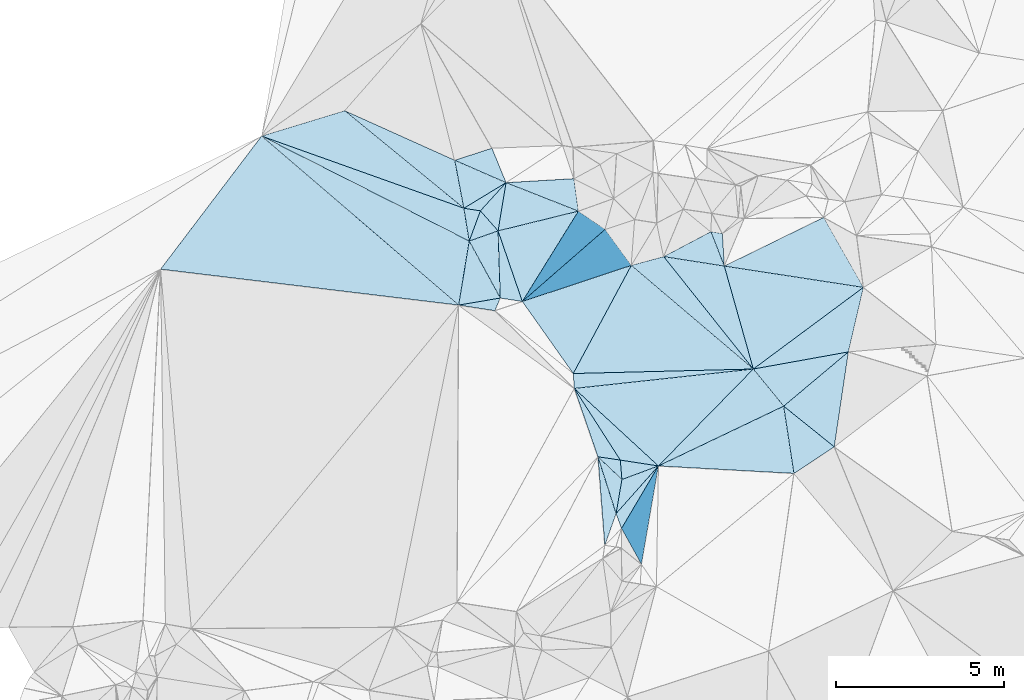
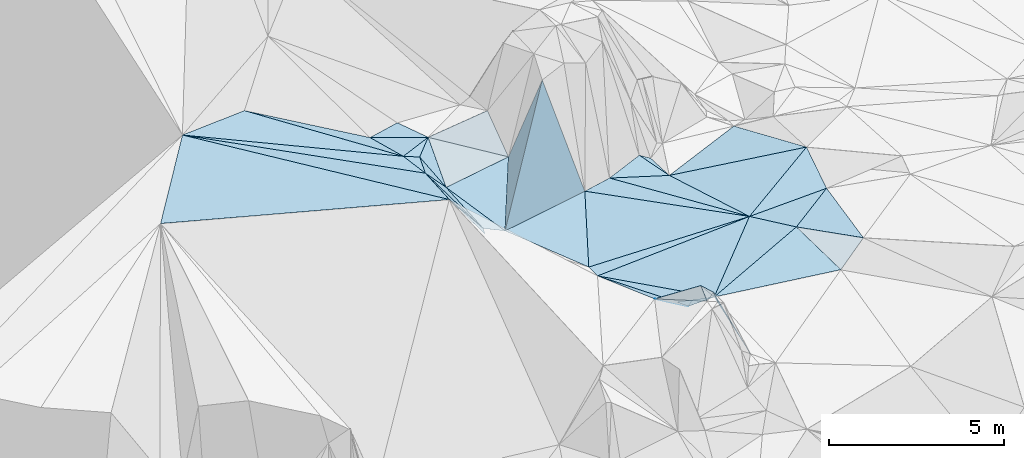
# One storey, part 122 of 275: 45 plates.
"""IFC2X3 building model written with IfcOpenShell, lengths in millimetres."""

from ifc_helpers import new_model, si_unit, frame, origin_with_axes, place, context, subcontext, project, spatial, polyline, outline, extrude, material, type_object, element, save


model = new_model("IFC2X3")

# Units and contexts
model_context = context("Model", 3, precision=1e-05, world=origin_with_axes())
body_context = subcontext(model_context, "Body", "Model", "MODEL_VIEW")
ifc_project = project(units=[si_unit("LENGTHUNIT", "METRE", prefix="MILLI"), si_unit("AREAUNIT", "SQUARE_METRE"), si_unit("VOLUMEUNIT", "CUBIC_METRE"), si_unit("MASSUNIT", "GRAM", prefix="KILO"), si_unit("TIMEUNIT", "SECOND"), si_unit("PLANEANGLEUNIT", "RADIAN"), si_unit("SOLIDANGLEUNIT", "STERADIAN"), si_unit("THERMODYNAMICTEMPERATUREUNIT", "DEGREE_CELSIUS"), si_unit("LUMINOUSINTENSITYUNIT", "LUMEN")], contexts=[model_context])

# Site, building, storey
site_placement = place(None, origin_with_axes())
site = spatial("IfcSite", under=ifc_project, at=site_placement, CompositionType="ELEMENT")
building_placement = place(site_placement, origin_with_axes())
building = spatial("IfcBuilding", under=site, at=building_placement, Name="Undefined", CompositionType="ELEMENT")
storey_placement = place(building_placement, origin_with_axes())
storey = spatial("IfcBuildingStorey", under=building, at=storey_placement, Name="Undefined", CompositionType="ELEMENT", Elevation=0.0)

# Plates
ifc_material = material()
plate_type_1 = type_object("IfcPlateType", PredefinedType="NOTDEFINED")
plate_1_placement = place(storey_placement, frame((-117256.863583798, 103758.167363246, 53639.5008489211), z_axis=(-0.0499357996180715, 0.0315971887779537, -0.99825248989313), x_axis=(-0.760955833681114, 0.646159315420978, 0.0585180167245527)))
element("IfcPlate", 1, at=plate_1_placement, inside=storey, type_object=plate_type_1, material=ifc_material, Name="00", context=body_context, shape_type="SweptSolid", body=[
    extrude(outline(polyline([(0.0, 0.0), (4784.85107421875, -8.87303031049669e-09), (4217.3515625, 825.920349121094), (0.0, 0.0)])), frame((-8.85201319254618e-08, 2.18876761149539e-07, -0.5000001331573), z_axis=(0.0, 0.0, 1.0), x_axis=(1.0, 0.0, 0.0)), (0.0, 0.0, 1.0), 1.0),
])
plate_type_2 = type_object("IfcPlateType", PredefinedType="NOTDEFINED")
plate_2_placement = place(storey_placement, frame((-116351.3289521, 102649.731812888, 53629.5089656912), z_axis=(-0.0704390174339977, 0.175137384942136, -0.982020998359283), x_axis=(0.14899523720596, -0.971575277584315, -0.183961678827142)))
element("IfcPlate", 2, at=plate_2_placement, inside=storey, type_object=plate_type_2, material=ifc_material, Name="00", context=body_context, shape_type="SweptSolid", body=[
    extrude(outline(polyline([(0.0, 0.0), (2065.64770507813, -8.04720912128687e-09), (1185.29418945313, 3968.82568359375), (0.0, 0.0)])), frame((-8.85201319254618e-08, 2.18876761149539e-07, -0.5000001331573), z_axis=(0.0, 0.0, 1.0), x_axis=(1.0, 0.0, 0.0)), (0.0, 0.0, 1.0), 1.0),
])
plate_type_3 = type_object("IfcPlateType", PredefinedType="NOTDEFINED")
plate_3_placement = place(storey_placement, frame((-125734.75211419, 107576.260128558, 55799.5215665715), z_axis=(-0.290703244147936, 0.00149951319354823, -0.956812089859889), x_axis=(-0.160597695300292, 0.985735474282099, 0.0503384048821584)))
element("IfcPlate", 3, at=plate_3_placement, inside=storey, type_object=plate_type_3, material=ifc_material, Name="00", context=body_context, shape_type="SweptSolid", body=[
    extrude(outline(polyline([(0.0, 0.0), (993.277404785156, -4.20550350099802e-09), (830.483032226563, 495.275665283203), (0.0, 0.0)])), frame((-8.85201319254618e-08, 2.18876761149539e-07, -0.5000001331573), z_axis=(0.0, 0.0, 1.0), x_axis=(1.0, 0.0, 0.0)), (0.0, 0.0, 1.0), 1.0),
])
plate_type_4 = type_object("IfcPlateType", PredefinedType="NOTDEFINED")
plate_4_placement = place(storey_placement, frame((-124808.265684324, 105875.788917307, 54579.6751534299), z_axis=(-0.758408827902835, 0.0527655703964489, -0.649639780447431), x_axis=(-0.404882136152401, 0.742943479664554, 0.533015423649816)))
element("IfcPlate", 4, at=plate_4_placement, inside=storey, type_object=plate_type_4, material=ifc_material, Name="00", context=body_context, shape_type="SweptSolid", body=[
    extrude(outline(polyline([(0.0, 0.0), (2288.8642578125, -3.98358679376543e-09), (1643.87194824219, 1173.62036132813), (0.0, 0.0)])), frame((-8.85201319254618e-08, 2.18876761149539e-07, -0.5000001331573), z_axis=(0.0, 0.0, 1.0), x_axis=(1.0, 0.0, 0.0)), (0.0, 0.0, 1.0), 1.0),
])
plate_type_5 = type_object("IfcPlateType", PredefinedType="NOTDEFINED")
plate_5_placement = place(storey_placement, frame((-122477.643975416, 108469.834223573, 54689.6645783467), z_axis=(0.00614995296914317, 0.741623745857371, -0.670787893196471), x_axis=(-0.864866646984772, 0.340668875789644, 0.368714523719283)))
element("IfcPlate", 5, at=plate_5_placement, inside=storey, type_object=plate_type_5, material=ifc_material, Name="00", context=body_context, shape_type="SweptSolid", body=[
    extrude(outline(polyline([(0.0, 0.0), (2495.1552734375, -4.0818122215569e-09), (839.747314453125, 1181.61938476563), (0.0, 0.0)])), frame((-8.85201319254618e-08, 2.18876761149539e-07, -0.5000001331573), z_axis=(0.0, 0.0, 1.0), x_axis=(1.0, 0.0, 0.0)), (0.0, 0.0, 1.0), 1.0),
])
plate_type_6 = type_object("IfcPlateType", PredefinedType="NOTDEFINED")
plate_6_placement = place(storey_placement, frame((-118522.281638937, 107856.549112146, 53729.5629301521), z_axis=(-0.485765802058403, -0.00150482624525639, -0.874087707869484), x_axis=(0.865215973140842, -0.142951842851727, -0.480589315785569)))
element("IfcPlate", 6, at=plate_6_placement, inside=storey, type_object=plate_type_6, material=ifc_material, Name="00", context=body_context, shape_type="SweptSolid", body=[
    extrude(outline(polyline([(0.0, 0.0), (395.347961425781, 1.26601662486792e-09), (597.701354980469, 950.606689453125), (0.0, 0.0)])), frame((-8.85201319254618e-08, 2.18876761149539e-07, -0.5000001331573), z_axis=(0.0, 0.0, 1.0), x_axis=(1.0, 0.0, 0.0)), (0.0, 0.0, 1.0), 1.0),
])
plate_type_7 = type_object("IfcPlateType", PredefinedType="NOTDEFINED")
plate_7_placement = place(storey_placement, frame((-122598.909963092, 103178.610685969, 53789.5566400081), z_axis=(-0.405259346543925, -0.222665919862276, -0.886670598458457), x_axis=(0.539635964377467, -0.841153502181183, -0.035409203870355)))
element("IfcPlate", 7, at=plate_7_placement, inside=storey, type_object=plate_type_7, material=ifc_material, Name="00", context=body_context, shape_type="SweptSolid", body=[
    extrude(outline(polyline([(0.0, 0.0), (2541.7119140625, -1.20635377243161e-08), (2088.82836914063, 572.535034179688), (0.0, 0.0)])), frame((-8.85201319254618e-08, 2.18876761149539e-07, -0.5000001331573), z_axis=(0.0, 0.0, 1.0), x_axis=(1.0, 0.0, 0.0)), (0.0, 0.0, 1.0), 1.0),
])
plate_type_8 = type_object("IfcPlateType", PredefinedType="NOTDEFINED")
plate_8_placement = place(storey_placement, frame((-121352.01315693, 99443.4503077407, 55279.7150323259), z_axis=(0.143864828544369, -0.809031263404254, -0.569887116841938), x_axis=(0.0998158209935995, 0.584804072810687, -0.805009936773085)))
element("IfcPlate", 8, at=plate_8_placement, inside=storey, type_object=plate_type_8, material=ifc_material, Name="00", context=body_context, shape_type="SweptSolid", body=[
    extrude(outline(polyline([(0.0, 0.0), (1739.10900878906, -1.16415321826935e-10), (2326.19116210938, 1046.82116699219), (0.0, 0.0)])), frame((-8.85201319254618e-08, 2.18876761149539e-07, -0.5000001331573), z_axis=(0.0, 0.0, 1.0), x_axis=(1.0, 0.0, 0.0)), (0.0, 0.0, 1.0), 1.0),
])
plate_type_9 = type_object("IfcPlateType", PredefinedType="NOTDEFINED")
plate_9_placement = place(storey_placement, frame((-121893.682362337, 101139.36737694, 53979.6500920951), z_axis=(0.63105989266783, -0.334801138104281, -0.699765396250876), x_axis=(0.245841933033501, -0.769255193884005, 0.589752652088004)))
element("IfcPlate", 9, at=plate_9_placement, inside=storey, type_object=plate_type_9, material=ifc_material, Name="00", context=body_context, shape_type="SweptSolid", body=[
    extrude(outline(polyline([(0.0, 0.0), (2204.31396484375, 9.09494701772928e-09), (2938.419921875, 701.846435546875), (0.0, 0.0)])), frame((-8.85201319254618e-08, 2.18876761149539e-07, -0.5000001331573), z_axis=(0.0, 0.0, 1.0), x_axis=(1.0, 0.0, 0.0)), (0.0, 0.0, 1.0), 1.0),
])
plate_type_10 = type_object("IfcPlateType", PredefinedType="NOTDEFINED")
plate_10_placement = place(storey_placement, frame((-125894.323219092, 108555.292486918, 55849.5472761285), z_axis=(-0.396716133861997, -0.151301981111269, -0.905386116331256), x_axis=(-0.753662489382819, 0.616756116421438, 0.227166777839627)))
element("IfcPlate", 10, at=plate_10_placement, inside=storey, type_object=plate_type_10, material=ifc_material, Name="00", context=body_context, shape_type="SweptSolid", body=[
    extrude(outline(polyline([(0.0, 0.0), (4719.0, 1.77533365786076e-09), (1061.30114746094, 1006.64782714844), (0.0, 0.0)])), frame((-8.85201319254618e-08, 2.18876761149539e-07, -0.5000001331573), z_axis=(0.0, 0.0, 1.0), x_axis=(1.0, 0.0, 0.0)), (0.0, 0.0, 1.0), 1.0),
])
plate_type_11 = type_object("IfcPlateType", PredefinedType="NOTDEFINED")
plate_11_placement = place(storey_placement, frame((-114841.889778264, 101436.371263435, 53459.5047513774), z_axis=(-0.134800778241863, -0.0289314848350606, -0.990450260927134), x_axis=(-0.776449915594691, 0.624082376178226, 0.0874455048400823)))
element("IfcPlate", 11, at=plate_11_placement, inside=storey, type_object=plate_type_11, material=ifc_material, Name="00", context=body_context, shape_type="SweptSolid", body=[
    extrude(outline(polyline([(0.0, 0.0), (1944.06787109375, 5.98447513766587e-09), (1428.39660644531, 2485.27319335938), (0.0, 0.0)])), frame((-8.85201319254618e-08, 2.18876761149539e-07, -0.5000001331573), z_axis=(0.0, 0.0, 1.0), x_axis=(1.0, 0.0, 0.0)), (0.0, 0.0, 1.0), 1.0),
])
plate_type_12 = type_object("IfcPlateType", PredefinedType="NOTDEFINED")
plate_12_placement = place(storey_placement, frame((-126049.446428248, 105665.999521045, 56149.6905849539), z_axis=(-0.78540494516979, 0.0159119012763355, -0.618777733520374), x_axis=(0.159832049829965, 0.970980977168621, -0.177903507058803)))
element("IfcPlate", 12, at=plate_12_placement, inside=storey, type_object=plate_type_12, material=ifc_material, Name="00", context=body_context, shape_type="SweptSolid", body=[
    extrude(outline(polyline([(0.0, 0.0), (1967.35864257813, -8.06176103651524e-09), (681.370422363281, 1893.44506835938), (0.0, 0.0)])), frame((-8.85201319254618e-08, 2.18876761149539e-07, -0.5000001331573), z_axis=(0.0, 0.0, 1.0), x_axis=(1.0, 0.0, 0.0)), (0.0, 0.0, 1.0), 1.0),
])
plate_type_13 = type_object("IfcPlateType", PredefinedType="NOTDEFINED")
plate_13_placement = place(storey_placement, frame((-124635.663505295, 109319.483374494, 55609.501565799), z_axis=(-0.0797014114278515, -0.00358250286273969, -0.996812344771897), x_axis=(-0.914171717532181, 0.39894224700114, 0.0716599917802327)))
element("IfcPlate", 13, at=plate_13_placement, inside=storey, type_object=plate_type_13, material=ifc_material, Name="00", context=body_context, shape_type="SweptSolid", body=[
    extrude(outline(polyline([(0.0, 0.0), (1674.57458496094, -9.84437065199018e-09), (797.217407226563, 773.527221679688), (0.0, 0.0)])), frame((-8.85201319254618e-08, 2.18876761149539e-07, -0.5000001331573), z_axis=(0.0, 0.0, 1.0), x_axis=(1.0, 0.0, 0.0)), (0.0, 0.0, 1.0), 1.0),
])
plate_type_14 = type_object("IfcPlateType", PredefinedType="NOTDEFINED")
plate_14_placement = place(storey_placement, frame((-118123.079859049, 106830.334729182, 53509.5128990342), z_axis=(-0.177406512554612, 0.139843826697285, -0.974151237456418), x_axis=(-0.968420123101351, 0.151394723797785, 0.198096195770026)))
element("IfcPlate", 14, at=plate_14_placement, inside=storey, type_object=plate_type_14, material=ifc_material, Name="00", context=body_context, shape_type="SweptSolid", body=[
    extrude(outline(polyline([(0.0, 0.0), (1867.77941894531, 4.94765117764473e-10), (585.401000976563, 958.23046875), (0.0, 0.0)])), frame((-8.85201319254618e-08, 2.18876761149539e-07, -0.5000001331573), z_axis=(0.0, 0.0, 1.0), x_axis=(1.0, 0.0, 0.0)), (0.0, 0.0, 1.0), 1.0),
])
plate_type_15 = type_object("IfcPlateType", PredefinedType="NOTDEFINED")
plate_15_placement = place(storey_placement, frame((-119931.893640315, 107112.985956263, 53879.5142714335), z_axis=(-0.214591186696804, -0.101607995656786, -0.971404363697563), x_axis=(0.968420123100508, -0.15139472380995, -0.198096195764849)))
element("IfcPlate", 15, at=plate_15_placement, inside=storey, type_object=plate_type_15, material=ifc_material, Name="00", context=body_context, shape_type="SweptSolid", body=[
    extrude(outline(polyline([(0.0, 0.0), (1867.77941894531, 4.94765117764473e-10), (3145.92822265625, 2927.68432617188), (0.0, 0.0)])), frame((-8.85201319254618e-08, 2.18876761149539e-07, -0.5000001331573), z_axis=(0.0, 0.0, 1.0), x_axis=(1.0, 0.0, 0.0)), (0.0, 0.0, 1.0), 1.0),
])
plate_type_16 = type_object("IfcPlateType", PredefinedType="NOTDEFINED")
plate_16_placement = place(storey_placement, frame((-125894.232681434, 108555.415336583, 55849.5140298296), z_axis=(-0.215715907935035, 0.0943696531734513, -0.971885289333924), x_axis=(-0.915472050646769, 0.326688557993063, 0.23491596489173)))
element("IfcPlate", 16, at=plate_16_placement, inside=storey, type_object=plate_type_16, material=ifc_material, Name="00", context=body_context, shape_type="SweptSolid", body=[
    extrude(outline(polyline([(0.0, 0.0), (6593.84716796875, 4.04470483772457e-08), (4458.5546875, 1546.04370117188), (0.0, 0.0)])), frame((-8.85201319254618e-08, 2.18876761149539e-07, -0.5000001331573), z_axis=(0.0, 0.0, 1.0), x_axis=(1.0, 0.0, 0.0)), (0.0, 0.0, 1.0), 1.0),
])
plate_type_17 = type_object("IfcPlateType", PredefinedType="NOTDEFINED")
plate_17_placement = place(storey_placement, frame((-122598.761891326, 103178.707930402, 53789.503160689), z_axis=(-0.109118664657425, -0.0281764655188658, -0.993629309055568), x_axis=(0.733942578019275, -0.676428880735025, -0.0614187388179017)))
element("IfcPlate", 17, at=plate_17_placement, inside=storey, type_object=plate_type_17, material=ifc_material, Name="00", context=body_context, shape_type="SweptSolid", body=[
    extrude(outline(polyline([(0.0, 0.0), (3419.15185546875, 3.12866177409887e-10), (2458.38745117188, 645.469970703125), (0.0, 0.0)])), frame((-8.85201319254618e-08, 2.18876761149539e-07, -0.5000001331573), z_axis=(0.0, 0.0, 1.0), x_axis=(1.0, 0.0, 0.0)), (0.0, 0.0, 1.0), 1.0),
])
plate_type_18 = type_object("IfcPlateType", PredefinedType="NOTDEFINED")
plate_18_placement = place(storey_placement, frame((-122477.236698246, 108469.231085691, 54689.833746149), z_axis=(0.820712902979613, -0.464655178897038, -0.33245435116259), x_axis=(0.275579687937294, -0.18777919392795, 0.942759147356393)))
element("IfcPlate", 18, at=plate_18_placement, inside=storey, type_object=plate_type_18, material=ifc_material, Name="00", context=body_context, shape_type="SweptSolid", body=[
    extrude(outline(polyline([(0.0, 0.0), (2895.75561523438, -4.08908817917109e-09), (-293.947479248047, 3179.88916015625), (0.0, 0.0)])), frame((-8.85201319254618e-08, 2.18876761149539e-07, -0.5000001331573), z_axis=(0.0, 0.0, 1.0), x_axis=(1.0, 0.0, 0.0)), (0.0, 0.0, 1.0), 1.0),
])
plate_type_19 = type_object("IfcPlateType", PredefinedType="NOTDEFINED")
plate_19_placement = place(storey_placement, frame((-124808.277542322, 105875.858882045, 54579.7036886285), z_axis=(-0.78213162721643, 0.192694866840591, -0.592569663416096), x_axis=(-0.383619710907238, -0.898300376216136, 0.214225002026833)))
element("IfcPlate", 19, at=plate_19_placement, inside=storey, type_object=plate_type_19, material=ifc_material, Name="00", context=body_context, shape_type="SweptSolid", body=[
    extrude(outline(polyline([(0.0, 0.0), (420.119018554688, -1.30967237055302e-09), (1000.90679931641, 1745.73352050781), (0.0, 0.0)])), frame((-8.85201319254618e-08, 2.18876761149539e-07, -0.5000001331573), z_axis=(0.0, 0.0, 1.0), x_axis=(1.0, 0.0, 0.0)), (0.0, 0.0, 1.0), 1.0),
])
plate_type_20 = type_object("IfcPlateType", PredefinedType="NOTDEFINED")
plate_20_placement = place(storey_placement, frame((-113971.528783824, 106194.671984585, 53429.5058944166), z_axis=(-0.126989995286845, 0.0860649435185467, -0.988163127522069), x_axis=(-0.226908607800729, -0.972331922189709, -0.055525820991689)))
element("IfcPlate", 20, at=plate_20_placement, inside=storey, type_object=plate_type_20, material=ifc_material, Name="00", context=body_context, shape_type="SweptSolid", body=[
    extrude(outline(polyline([(0.0, 0.0), (1981.06030273438, -7.33416527509689e-09), (3102.8837890625, 2673.2587890625), (0.0, 0.0)])), frame((-8.85201319254618e-08, 2.18876761149539e-07, -0.5000001331573), z_axis=(0.0, 0.0, 1.0), x_axis=(1.0, 0.0, 0.0)), (0.0, 0.0, 1.0), 1.0),
])
plate_type_21 = type_object("IfcPlateType", PredefinedType="NOTDEFINED")
plate_21_placement = place(storey_placement, frame((-121894.312737827, 101139.24012601, 53979.7468857445), z_axis=(-0.629686954423692, -0.589302291462987, -0.506178969046609), x_axis=(0.721847435527922, -0.684659158190324, -0.100886653864021)))
element("IfcPlate", 21, at=plate_21_placement, inside=storey, type_object=plate_type_21, material=ifc_material, Name="00", context=body_context, shape_type="SweptSolid", body=[
    extrude(outline(polyline([(0.0, 0.0), (991.211364746094, 9.09494701772928e-10), (1420.98852539063, 1685.16809082031), (0.0, 0.0)])), frame((-8.85201319254618e-08, 2.18876761149539e-07, -0.5000001331573), z_axis=(0.0, 0.0, 1.0), x_axis=(1.0, 0.0, 0.0)), (0.0, 0.0, 1.0), 1.0),
])
plate_type_22 = type_object("IfcPlateType", PredefinedType="NOTDEFINED")
plate_22_placement = place(storey_placement, frame((-131930.730392258, 110709.507378865, 57398.5152771061), z_axis=(-0.245349999966605, 0.00953073751253798, -0.969387715291902), x_axis=(0.915472050646519, -0.326688557995124, -0.234915964889838)))
element("IfcPlate", 22, at=plate_22_placement, inside=storey, type_object=plate_type_22, material=ifc_material, Name="00", context=body_context, shape_type="SweptSolid", body=[
    extrude(outline(polyline([(0.0, 0.0), (6593.84716796875, 4.04470483772457e-08), (7071.4912109375, 870.89404296875), (0.0, 0.0)])), frame((-8.85201319254618e-08, 2.18876761149539e-07, -0.5000001331573), z_axis=(0.0, 0.0, 1.0), x_axis=(1.0, 0.0, 0.0)), (0.0, 0.0, 1.0), 1.0),
])
plate_type_23 = type_object("IfcPlateType", PredefinedType="NOTDEFINED")
plate_23_placement = place(storey_placement, frame((-122598.727178642, 103178.776391733, 53789.5033361739), z_axis=(-0.0396868936590068, 0.108745959375244, -0.993277034261468), x_axis=(-0.0727160722706848, 0.991110117344391, 0.111414128956396)))
element("IfcPlate", 23, at=plate_23_placement, inside=storey, type_object=plate_type_23, material=ifc_material, Name="00", context=body_context, shape_type="SweptSolid", body=[
    extrude(outline(polyline([(0.0, 0.0), (448.776123046875, -1.00408215075731e-09), (169.126647949219, 5372.6337890625), (0.0, 0.0)])), frame((-8.85201319254618e-08, 2.18876761149539e-07, -0.5000001331573), z_axis=(0.0, 0.0, 1.0), x_axis=(1.0, 0.0, 0.0)), (0.0, 0.0, 1.0), 1.0),
])
plate_type_24 = type_object("IfcPlateType", PredefinedType="NOTDEFINED")
plate_24_placement = place(storey_placement, frame((-121189.824534682, 99001.7487643097, 55259.6530510681), z_axis=(-0.685442966634006, -0.22076742036619, -0.693851342577667), x_axis=(-0.34495088329282, 0.937661297130412, 0.0424285278935801)))
element("IfcPlate", 24, at=plate_24_placement, inside=storey, type_object=plate_type_24, material=ifc_material, Name="00", context=body_context, shape_type="SweptSolid", body=[
    extrude(outline(polyline([(0.0, 0.0), (471.380950927734, -1.33877620100975e-09), (1297.04016113281, 2413.56323242188), (0.0, 0.0)])), frame((-8.85201319254618e-08, 2.18876761149539e-07, -0.5000001331573), z_axis=(0.0, 0.0, 1.0), x_axis=(1.0, 0.0, 0.0)), (0.0, 0.0, 1.0), 1.0),
])
plate_type_25 = type_object("IfcPlateType", PredefinedType="NOTDEFINED")
plate_25_placement = place(storey_placement, frame((-116351.271613088, 102649.740445077, 53629.50981697), z_axis=(0.044239744408709, 0.192401520541444, -0.980318570622832), x_axis=(0.776449915596688, -0.624082376176445, -0.0874455048350662)))
element("IfcPlate", 25, at=plate_25_placement, inside=storey, type_object=plate_type_25, material=ifc_material, Name="00", context=body_context, shape_type="SweptSolid", body=[
    extrude(outline(polyline([(0.0, 0.0), (1944.06787109375, 5.98447513766587e-09), (1524.68957519531, 1393.63623046875), (0.0, 0.0)])), frame((-8.85201319254618e-08, 2.18876761149539e-07, -0.5000001331573), z_axis=(0.0, 0.0, 1.0), x_axis=(1.0, 0.0, 0.0)), (0.0, 0.0, 1.0), 1.0),
])
plate_type_26 = type_object("IfcPlateType", PredefinedType="NOTDEFINED")
plate_26_placement = place(storey_placement, frame((-125401.199991851, 108478.356677256, 55699.6972249683), z_axis=(-0.765892454486763, 0.216296958315686, -0.605495147778762), x_axis=(0.443714344088903, -0.503727973745376, -0.741198832511312)))
element("IfcPlate", 26, at=plate_26_placement, inside=storey, type_object=plate_type_26, material=ifc_material, Name="00", context=body_context, shape_type="SweptSolid", body=[
    extrude(outline(polyline([(0.0, 0.0), (1187.26574707031, 1.85173121280968e-09), (232.130004882813, 938.677612304688), (0.0, 0.0)])), frame((-8.85201319254618e-08, 2.18876761149539e-07, -0.5000001331573), z_axis=(0.0, 0.0, 1.0), x_axis=(1.0, 0.0, 0.0)), (0.0, 0.0, 1.0), 1.0),
])
plate_type_27 = type_object("IfcPlateType", PredefinedType="NOTDEFINED")
plate_27_placement = place(storey_placement, frame((-121189.930380467, 99001.9379287318, 55259.7936202835), z_axis=(-0.897130700603977, 0.157559213498781, -0.412712491058198), x_axis=(0.401545864914893, 0.680310127989211, -0.613138685881958)))
element("IfcPlate", 27, at=plate_27_placement, inside=storey, type_object=plate_type_27, material=ifc_material, Name="00", context=body_context, shape_type="SweptSolid", body=[
    extrude(outline(polyline([(0.0, 0.0), (2740.0, 1.12049747258425e-09), (551.970825195313, 2021.34313964844), (0.0, 0.0)])), frame((-8.85201319254618e-08, 2.18876761149539e-07, -0.5000001331573), z_axis=(0.0, 0.0, 1.0), x_axis=(1.0, 0.0, 0.0)), (0.0, 0.0, 1.0), 1.0),
])
plate_type_28 = type_object("IfcPlateType", PredefinedType="NOTDEFINED")
plate_28_placement = place(storey_placement, frame((-121894.20125788, 101139.383895832, 53979.5688409884), z_axis=(-0.406730669962794, -0.301764803929466, -0.862269195333469), x_axis=(0.913547637688999, -0.135318805762445, -0.383561643650502)))
element("IfcPlate", 28, at=plate_28_placement, inside=storey, type_object=plate_type_28, material=ifc_material, Name="00", context=body_context, shape_type="SweptSolid", body=[
    extrude(outline(polyline([(0.0, 0.0), (730.0, 2.895831130445e-09), (783.835632324219, 606.7138671875), (0.0, 0.0)])), frame((-8.85201319254618e-08, 2.18876761149539e-07, -0.5000001331573), z_axis=(0.0, 0.0, 1.0), x_axis=(1.0, 0.0, 0.0)), (0.0, 0.0, 1.0), 1.0),
])
plate_type_29 = type_object("IfcPlateType", PredefinedType="NOTDEFINED")
plate_29_placement = place(storey_placement, frame((-121227.181138747, 101040.59983319, 53699.5293401893), z_axis=(-0.146046368709961, -0.304433519529712, -0.941270784829417), x_axis=(0.983073084001921, -0.151058387791868, -0.10367581679772)))
element("IfcPlate", 29, at=plate_29_placement, inside=storey, type_object=plate_type_29, material=ifc_material, Name="00", context=body_context, shape_type="SweptSolid", body=[
    extrude(outline(polyline([(0.0, 0.0), (1157.4541015625, -7.5960997492075e-09), (116.721687316895, 597.809387207031), (0.0, 0.0)])), frame((-8.85201319254618e-08, 2.18876761149539e-07, -0.5000001331573), z_axis=(0.0, 0.0, 1.0), x_axis=(1.0, 0.0, 0.0)), (0.0, 0.0, 1.0), 1.0),
])
plate_type_30 = type_object("IfcPlateType", PredefinedType="NOTDEFINED")
plate_30_placement = place(storey_placement, frame((-120089.26307476, 100865.935832064, 53579.5009893524), z_axis=(-0.0338662721056671, 0.0538687504706836, -0.997973563445642), x_axis=(-0.733942578024038, 0.676428880729489, 0.0614187388219489)))
element("IfcPlate", 30, at=plate_30_placement, inside=storey, type_object=plate_type_30, material=ifc_material, Name="00", context=body_context, shape_type="SweptSolid", body=[
    extrude(outline(polyline([(0.0, 0.0), (3419.15185546875, 3.12866177409887e-10), (-118.742897033691, 4046.86303710938), (0.0, 0.0)])), frame((-8.85201319254618e-08, 2.18876761149539e-07, -0.5000001331573), z_axis=(0.0, 0.0, 1.0), x_axis=(1.0, 0.0, 0.0)), (0.0, 0.0, 1.0), 1.0),
])
plate_type_31 = type_object("IfcPlateType", PredefinedType="NOTDEFINED")
plate_31_placement = place(storey_placement, frame((-120089.242882468, 100865.916074399, 53579.5000377572), z_axis=(0.00652624539857522, 0.0143513402873292, -0.999875715853203), x_axis=(0.699600909115894, 0.714380107437534, 0.0148199211115425)))
element("IfcPlate", 31, at=plate_31_placement, inside=storey, type_object=plate_type_31, material=ifc_material, Name="00", context=body_context, shape_type="SweptSolid", body=[
    extrude(outline(polyline([(0.0, 0.0), (4048.60473632813, -4.36557456851006e-09), (3890.0810546875, 1422.5927734375), (0.0, 0.0)])), frame((-8.85201319254618e-08, 2.18876761149539e-07, -0.5000001331573), z_axis=(0.0, 0.0, 1.0), x_axis=(1.0, 0.0, 0.0)), (0.0, 0.0, 1.0), 1.0),
])
plate_type_32 = type_object("IfcPlateType", PredefinedType="NOTDEFINED")
plate_32_placement = place(storey_placement, frame((-116351.343255485, 102649.608265386, 53629.5037374452), z_axis=(-0.0990453610093147, -0.0719573435610518, -0.992477786738913), x_axis=(-0.632629733215255, 0.774422890914023, 0.00698617780783852)))
element("IfcPlate", 32, at=plate_32_placement, inside=storey, type_object=plate_type_32, material=ifc_material, Name="00", context=body_context, shape_type="SweptSolid", body=[
    extrude(outline(polyline([(0.0, 0.0), (1431.39794921875, -3.74348019249737e-09), (30.2501487731934, 2538.02783203125), (0.0, 0.0)])), frame((-8.85201319254618e-08, 2.18876761149539e-07, -0.5000001331573), z_axis=(0.0, 0.0, 1.0), x_axis=(1.0, 0.0, 0.0)), (0.0, 0.0, 1.0), 1.0),
])
plate_type_33 = type_object("IfcPlateType", PredefinedType="NOTDEFINED")
plate_33_placement = place(storey_placement, frame((-120897.918110459, 106849.950325778, 53919.500855387), z_axis=(-0.0382825610399043, 0.0453194942166054, -0.998238743469806), x_axis=(0.760955833681799, -0.646159315417973, -0.0585180167488181)))
element("IfcPlate", 33, at=plate_33_placement, inside=storey, type_object=plate_type_33, material=ifc_material, Name="00", context=body_context, shape_type="SweptSolid", body=[
    extrude(outline(polyline([(0.0, 0.0), (4784.85107421875, -8.87303031049669e-09), (770.389709472656, 3581.5498046875), (0.0, 0.0)])), frame((-8.85201319254618e-08, 2.18876761149539e-07, -0.5000001331573), z_axis=(0.0, 0.0, 1.0), x_axis=(1.0, 0.0, 0.0)), (0.0, 0.0, 1.0), 1.0),
])
plate_type_34 = type_object("IfcPlateType", PredefinedType="NOTDEFINED")
plate_34_placement = place(storey_placement, frame((-126049.141444669, 105666.011078377, 56149.5081153239), z_axis=(-0.175435757418341, 0.0390259359216622, -0.983717068747153), x_axis=(-0.97681215133859, 0.117655611801566, 0.178871959817283)))
element("IfcPlate", 34, at=plate_34_placement, inside=storey, type_object=plate_type_34, material=ifc_material, Name="00", context=body_context, shape_type="SweptSolid", body=[
    extrude(outline(polyline([(0.0, 0.0), (9107.0732421875, -5.09899109601974e-08), (6561.98193359375, 4304.65771484375), (0.0, 0.0)])), frame((-8.85201319254618e-08, 2.18876761149539e-07, -0.5000001331573), z_axis=(0.0, 0.0, 1.0), x_axis=(1.0, 0.0, 0.0)), (0.0, 0.0, 1.0), 1.0),
])
plate_type_35 = type_object("IfcPlateType", PredefinedType="NOTDEFINED")
plate_35_placement = place(storey_placement, frame((-117256.852054202, 103758.126650708, 53639.5007769009), z_axis=(-0.0268675255620626, -0.0498233371952771, -0.998396600124869), x_axis=(-0.271136433176785, 0.961680291799789, -0.0406946061295963)))
element("IfcPlate", 35, at=plate_35_placement, inside=storey, type_object=plate_type_35, material=ifc_material, Name="00", context=body_context, shape_type="SweptSolid", body=[
    extrude(outline(polyline([(0.0, 0.0), (3194.52661132813, 9.31322574615479e-09), (1460.87377929688, 3826.2314453125), (0.0, 0.0)])), frame((-8.85201319254618e-08, 2.18876761149539e-07, -0.5000001331573), z_axis=(0.0, 0.0, 1.0), x_axis=(1.0, 0.0, 0.0)), (0.0, 0.0, 1.0), 1.0),
])
plate_type_36 = type_object("IfcPlateType", PredefinedType="NOTDEFINED")
plate_36_placement = place(storey_placement, frame((-131930.760569438, 110709.441273761, 57398.5278756798), z_axis=(-0.305701893591646, -0.122673883705904, -0.94419143742728), x_axis=(0.869624301944958, -0.439758559711574, -0.224423667707189)))
element("IfcPlate", 36, at=plate_36_placement, inside=storey, type_object=plate_type_36, material=ifc_material, Name="00", context=body_context, shape_type="SweptSolid", body=[
    extrude(outline(polyline([(0.0, 0.0), (7124.9169921875, 4.61441231891513e-08), (7612.974609375, 1905.859375), (0.0, 0.0)])), frame((-8.85201319254618e-08, 2.18876761149539e-07, -0.5000001331573), z_axis=(0.0, 0.0, 1.0), x_axis=(1.0, 0.0, 0.0)), (0.0, 0.0, 1.0), 1.0),
])
plate_type_37 = type_object("IfcPlateType", PredefinedType="NOTDEFINED")
plate_37_placement = place(storey_placement, frame((-121679.802638682, 107926.139498164, 57419.8278282588), z_axis=(-0.333975222801879, 0.877452997831024, -0.344291718099322), x_axis=(0.208790755332444, -0.287323704106611, -0.934800251147893)))
element("IfcPlate", 37, at=plate_37_placement, inside=storey, type_object=plate_type_37, material=ifc_material, Name="00", context=body_context, shape_type="SweptSolid", body=[
    extrude(outline(polyline([(0.0, 0.0), (3744.11547851563, -9.61881596595049e-09), (2991.25390625, 3367.2392578125), (0.0, 0.0)])), frame((-8.85201319254618e-08, 2.18876761149539e-07, -0.5000001331573), z_axis=(0.0, 0.0, 1.0), x_axis=(1.0, 0.0, 0.0)), (0.0, 0.0, 1.0), 1.0),
])
plate_type_38 = type_object("IfcPlateType", PredefinedType="NOTDEFINED")
plate_38_placement = place(storey_placement, frame((-124150.312610665, 105772.986752331, 54329.5324092299), z_axis=(-0.33967821709817, 0.100762016016147, -0.93512872106324), x_axis=(-0.924932889598588, 0.144596292738501, 0.351555204576876)))
element("IfcPlate", 38, at=plate_38_placement, inside=storey, type_object=plate_type_38, material=ifc_material, Name="00", context=body_context, shape_type="SweptSolid", body=[
    extrude(outline(polyline([(0.0, 0.0), (711.125854492188, -4.51109372079372e-10), (1146.49182128906, 1972.34790039063), (0.0, 0.0)])), frame((-8.85201319254618e-08, 2.18876761149539e-07, -0.5000001331573), z_axis=(0.0, 0.0, 1.0), x_axis=(1.0, 0.0, 0.0)), (0.0, 0.0, 1.0), 1.0),
])
plate_type_39 = type_object("IfcPlateType", PredefinedType="NOTDEFINED")
plate_39_placement = place(storey_placement, frame((-113971.480603086, 106194.591627996, 53429.5016063799), z_axis=(-0.0306372736490924, -0.0746533291491415, -0.996738801246495), x_axis=(-0.988301680056839, 0.151317852777137, 0.0190445957622069)))
element("IfcPlate", 39, at=plate_39_placement, inside=storey, type_object=plate_type_39, material=ifc_material, Name="00", context=body_context, shape_type="SweptSolid", body=[
    extrude(outline(polyline([(0.0, 0.0), (4200.66650390625, -3.44880390912294e-09), (1485.81176757813, 1891.15393066406), (0.0, 0.0)])), frame((-8.85201319254618e-08, 2.18876761149539e-07, -0.5000001331573), z_axis=(0.0, 0.0, 1.0), x_axis=(1.0, 0.0, 0.0)), (0.0, 0.0, 1.0), 1.0),
])
plate_type_40 = type_object("IfcPlateType", PredefinedType="NOTDEFINED")
plate_40_placement = place(storey_placement, frame((-122631.420680948, 103623.563771053, 53839.5095297009), z_axis=(-0.160216925069041, 0.110400339053275, -0.980888526825726), x_axis=(-0.567329733429604, 0.802892109160947, 0.183033424853989)))
element("IfcPlate", 40, at=plate_40_placement, inside=storey, type_object=plate_type_40, material=ifc_material, Name="00", context=body_context, shape_type="SweptSolid", body=[
    extrude(outline(polyline([(0.0, 0.0), (2677.10668945313, -7.09405867382884e-09), (1621.67614746094, 3284.9912109375), (0.0, 0.0)])), frame((-8.85201319254618e-08, 2.18876761149539e-07, -0.5000001331573), z_axis=(0.0, 0.0, 1.0), x_axis=(1.0, 0.0, 0.0)), (0.0, 0.0, 1.0), 1.0),
])
plate_type_41 = type_object("IfcPlateType", PredefinedType="NOTDEFINED")
plate_41_placement = place(storey_placement, frame((-124874.303398243, 107880.420669007, 54819.6673793539), z_axis=(-0.586404325640962, 0.462231413681076, -0.665185753813145), x_axis=(-0.443714344084958, 0.503727973740608, 0.741198832516914)))
element("IfcPlate", 41, at=plate_41_placement, inside=storey, type_object=plate_type_41, material=ifc_material, Name="00", context=body_context, shape_type="SweptSolid", body=[
    extrude(outline(polyline([(0.0, 0.0), (1187.26574707031, 1.85173121280968e-09), (1204.78503417969, 1140.61083984375), (0.0, 0.0)])), frame((-8.85201319254618e-08, 2.18876761149539e-07, -0.5000001331573), z_axis=(0.0, 0.0, 1.0), x_axis=(1.0, 0.0, 0.0)), (0.0, 0.0, 1.0), 1.0),
])
plate_type_42 = type_object("IfcPlateType", PredefinedType="NOTDEFINED")
plate_42_placement = place(storey_placement, frame((-124874.060345747, 107880.285820242, 54819.5118962931), z_axis=(-0.100299094562535, 0.192530757592315, -0.976151627059477), x_axis=(0.969726667773316, 0.238459090157087, -0.0526065787779104)))
element("IfcPlate", 42, at=plate_42_placement, inside=storey, type_object=plate_type_42, material=ifc_material, Name="00", context=body_context, shape_type="SweptSolid", body=[
    extrude(outline(polyline([(0.0, 0.0), (2471.173828125, 6.89760781824589e-09), (225.237091064453, 2270.21337890625), (0.0, 0.0)])), frame((-8.85201319254618e-08, 2.18876761149539e-07, -0.5000001331573), z_axis=(0.0, 0.0, 1.0), x_axis=(1.0, 0.0, 0.0)), (0.0, 0.0, 1.0), 1.0),
])
plate_type_43 = type_object("IfcPlateType", PredefinedType="NOTDEFINED")
plate_43_placement = place(storey_placement, frame((-124635.707700812, 109319.732949357, 55609.5738980585), z_axis=(-0.168089914139989, 0.495567651270807, -0.852149331853489), x_axis=(0.864866647014761, -0.340668875709146, -0.368714523723314)))
element("IfcPlate", 43, at=plate_43_placement, inside=storey, type_object=plate_type_43, material=ifc_material, Name="00", context=body_context, shape_type="SweptSolid", body=[
    extrude(outline(polyline([(0.0, 0.0), (2495.1552734375, -4.0818122215569e-09), (575.435119628906, 1556.07666015625), (0.0, 0.0)])), frame((-8.85201319254618e-08, 2.18876761149539e-07, -0.5000001331573), z_axis=(0.0, 0.0, 1.0), x_axis=(1.0, 0.0, 0.0)), (0.0, 0.0, 1.0), 1.0),
])
plate_type_44 = type_object("IfcPlateType", PredefinedType="NOTDEFINED")
plate_44_placement = place(storey_placement, frame((-124635.757537089, 109319.555902119, 55609.5234404733), z_axis=(-0.267673826246812, 0.1415140335075, -0.953060596742321), x_axis=(-0.670783692382462, -0.737444705270677, 0.0788957838036665)))
element("IfcPlate", 44, at=plate_44_placement, inside=storey, type_object=plate_type_44, material=ifc_material, Name="00", context=body_context, shape_type="SweptSolid", body=[
    extrude(outline(polyline([(0.0, 0.0), (1140.74536132813, 6.46105036139488e-09), (1426.61108398438, 435.982543945313), (0.0, 0.0)])), frame((-8.85201319254618e-08, 2.18876761149539e-07, -0.5000001331573), z_axis=(0.0, 0.0, 1.0), x_axis=(1.0, 0.0, 0.0)), (0.0, 0.0, 1.0), 1.0),
])
plate_type_45 = type_object("IfcPlateType", PredefinedType="NOTDEFINED")
plate_45_placement = place(storey_placement, frame((-125894.186734844, 108555.315055591, 55849.5066645428), z_axis=(-0.123679218169043, -0.106187164879425, -0.986624415371911), x_axis=(-0.186185998494713, 0.979083683087382, -0.0820360620494029)))
element("IfcPlate", 45, at=plate_45_placement, inside=storey, type_object=plate_type_45, material=ifc_material, Name="00", context=body_context, shape_type="SweptSolid", body=[
    extrude(outline(polyline([(0.0, 0.0), (1462.77136230469, 3.31783667206764e-09), (533.507873535156, 1393.0791015625), (0.0, 0.0)])), frame((-8.85201319254618e-08, 2.18876761149539e-07, -0.5000001331573), z_axis=(0.0, 0.0, 1.0), x_axis=(1.0, 0.0, 0.0)), (0.0, 0.0, 1.0), 1.0),
])

save(model, "model.ifc")
